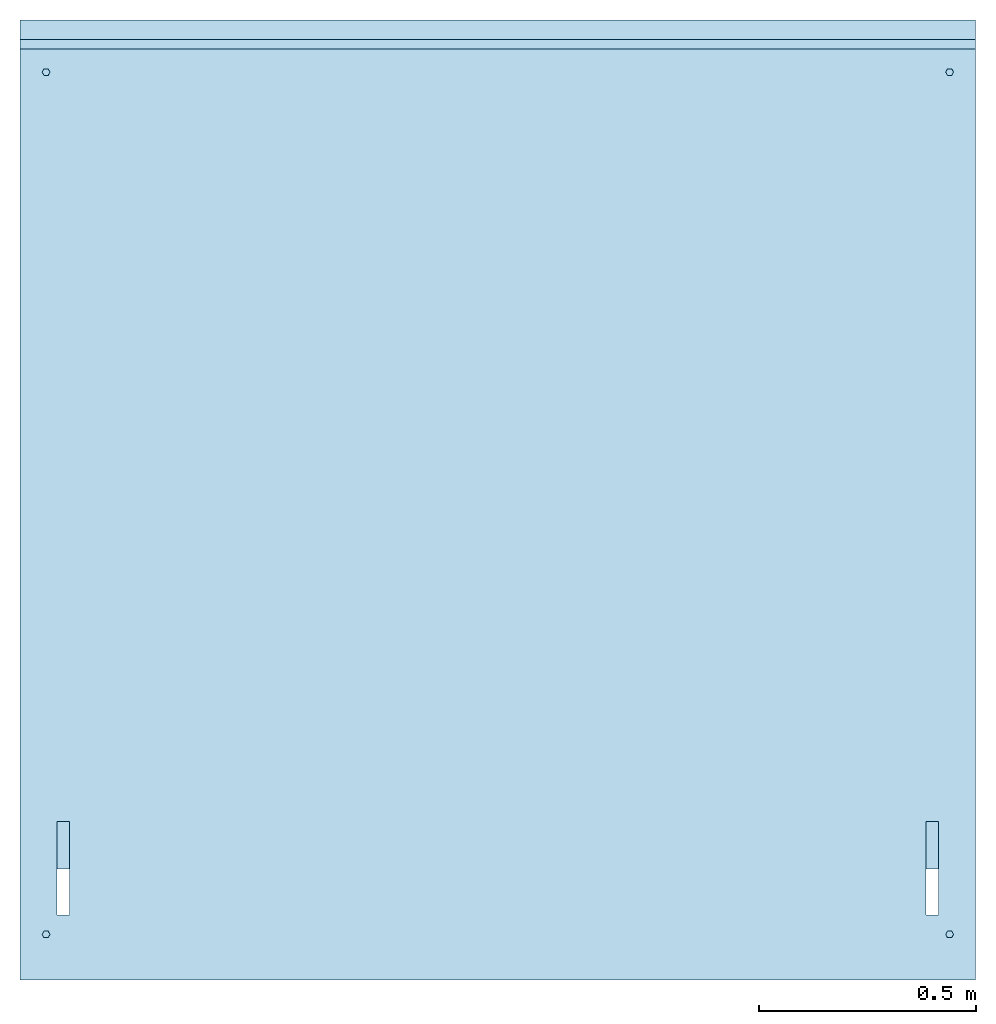
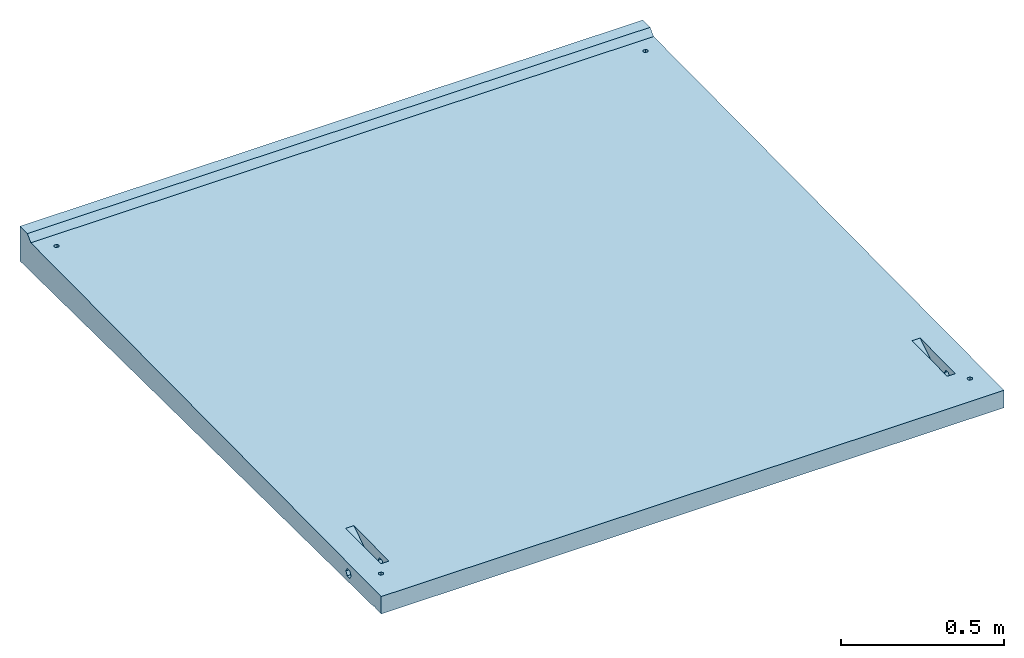
# One storey: 1 slab.
"""IFC2X3 building model written with IfcOpenShell, lengths in millimetres."""

import ifcopenshell
import ifcopenshell.guid

model = None  # the IFC model being written
_history = None  # IfcOwnerHistory: only IFC2X3 demands one
_inside = {}  # id of a spatial element -> (the spatial element, [elements in it])
_under = {}  # id of a project, library or spatial element -> (it, [spatial elements below it])
_declared = {}  # id of a project -> (the project, [libraries it declares])
_typed = {}  # id of a type object -> (the type object, [elements of that type])
_made_of = {}  # id of a material, layer set ... -> (it, [elements and type objects made of it])


def new_model(schema):
    """Start an empty IFC model of exactly this schema.

    Asked for "IFC4X3", IfcOpenShell would pick the latest addendum, in which some entities
    have other attributes; the version numbers below select the first issue.
    IFC2X3 requires an IfcOwnerHistory on every rooted entity: one is made here for all.
    """
    global model, _history
    if schema == "IFC4X3":
        model = ifcopenshell.file(schema_version=(4, 3, 0, 0))
    else:
        model = ifcopenshell.file(schema=schema)
    _inside.clear()
    _under.clear()
    _declared.clear()
    _typed.clear()
    _made_of.clear()
    _history = None
    if model.schema == "IFC2X3":
        org = make("IfcOrganization", Name="unknown")
        user = make(
            "IfcPersonAndOrganization",
            ThePerson=make("IfcPerson", FamilyName="unknown"),
            TheOrganization=org,
        )
        app = make(
            "IfcApplication",
            ApplicationDeveloper=org,
            Version="unknown",
            ApplicationFullName="unknown",
            ApplicationIdentifier="unknown",
        )
        _history = make(
            "IfcOwnerHistory",
            OwningUser=user,
            OwningApplication=app,
            ChangeAction="ADDED",
            CreationDate=0,
        )
    return model


def make(cls, **values):
    """One entity of the class cls with the attributes given. An attribute that is None is left unset."""
    return model.create_entity(
        cls, **{name: value for name, value in values.items() if value is not None}
    )


def entity(cls, *values):
    """Any entity or typed value of the class cls, its attributes in the order of the schema. None: left unset."""
    e = model.create_entity(cls)
    for i, value in enumerate(values):
        if value is not None:
            e[i] = value
    return e


def rooted(cls, **values):
    """An entity with a GlobalId (a new one), such as an element, a storey or a relation."""
    return make(cls, GlobalId=ifcopenshell.guid.new(), OwnerHistory=_history, **values)


def si_unit(unit_type, name, prefix=None):
    """IfcSIUnit, for example si_unit("LENGTHUNIT", "METRE", prefix="MILLI")."""
    return make("IfcSIUnit", UnitType=unit_type, Prefix=prefix, Name=name)


def converted_unit(unit_type, name, factor, base, dimensions=None, offset=None):
    """IfcConversionBasedUnit, such as the inch: factor (a typed value) times the base unit."""
    return make(
        "IfcConversionBasedUnit"
        if offset is None
        else "IfcConversionBasedUnitWithOffset",
        ConversionOffset=offset,
        Dimensions=None
        if dimensions is None
        else entity("IfcDimensionalExponents", *dimensions),
        UnitType=unit_type,
        Name=name,
        ConversionFactor=make(
            "IfcMeasureWithUnit", ValueComponent=factor, UnitComponent=base
        ),
    )


def derived_unit(unit_type, elements):
    """IfcDerivedUnit: a product of units, each with its exponent."""
    return make(
        "IfcDerivedUnit",
        Elements=[
            make("IfcDerivedUnitElement", Unit=unit, Exponent=power)
            for unit, power in elements
        ],
        UnitType=unit_type,
    )


def assignment(units):
    """IfcUnitAssignment: the units of a project."""
    return None if units is None else make("IfcUnitAssignment", Units=units)


def point(xyz):
    """IfcCartesianPoint."""
    return None if xyz is None else make("IfcCartesianPoint", Coordinates=xyz)


def direction(xyz):
    """IfcDirection."""
    return None if xyz is None else make("IfcDirection", DirectionRatios=xyz)


def frame(location, z_axis=None, x_axis=None):
    """IfcAxis2Placement3D, a coordinate frame: its origin and axes. An axis left out is left unset."""
    return make(
        "IfcAxis2Placement3D",
        Location=point(location),
        Axis=direction(z_axis),
        RefDirection=direction(x_axis),
    )


def origin():
    """The frame at (0, 0, 0) with its axes left unset."""
    return frame((0.0, 0.0, 0.0))


def place(relative_to, where):
    """IfcLocalPlacement: puts the frame where relative to a parent placement (None: the world)."""
    return make(
        "IfcLocalPlacement", PlacementRelTo=relative_to, RelativePlacement=where
    )


def context(
    kind, dimensions, precision=None, world=None, true_north=None, identifier=None
):
    """IfcGeometricRepresentationContext, for example the 3D "Model" context."""
    return make(
        "IfcGeometricRepresentationContext",
        ContextIdentifier=identifier,
        ContextType=kind,
        CoordinateSpaceDimension=dimensions,
        Precision=precision,
        WorldCoordinateSystem=world,
        TrueNorth=true_north,
    )


def subcontext(parent, identifier, kind, view, scale=None):
    """IfcGeometricRepresentationSubContext, for example "Body" below "Model"."""
    return make(
        "IfcGeometricRepresentationSubContext",
        ContextIdentifier=identifier,
        ContextType=kind,
        ParentContext=parent,
        TargetScale=scale,
        TargetView=view,
    )


def project(units=None, contexts=None):
    """IfcProject with its units and contexts."""
    return rooted(
        "IfcProject",
        Name="project",
        RepresentationContexts=contexts,
        UnitsInContext=assignment(units),
    )


def spatial(cls, under=None, at=None, **own):
    """A site, building, storey or space (cls), placed at a placement, below another one or the project."""
    s = rooted(cls, ObjectPlacement=at, **own)
    if under is not None:
        _under.setdefault(under.id(), (under, []))[1].append(s)
    return s


def faces_of(points, faces, orient=None, outer=None):
    """IfcFace entities. A face is a list of loops; a loop is a list of indices into points, from 0.

    orient and outer hold one flag for each loop. By default every Orientation is true, the
    first loop of a face is its IfcFaceOuterBound and the others are IfcFaceBound.
    """
    made = []
    for i, loops in enumerate(faces):
        bounds = []
        for j, loop in enumerate(loops):
            is_outer = j == 0 if outer is None else outer[i][j]
            bounds.append(
                make(
                    "IfcFaceOuterBound" if is_outer else "IfcFaceBound",
                    Bound=make("IfcPolyLoop", Polygon=[points[k] for k in loop]),
                    Orientation=True if orient is None else orient[i][j],
                )
            )
        made.append(make("IfcFace", Bounds=bounds))
    return made


def faceted_brep(points, faces, orient=None, outer=None, voids=None):
    """IfcFacetedBrep: a solid bounded by flat faces; with voids (closed shells), ...WithVoids."""
    shared = [point(p) for p in points]
    hull = make("IfcClosedShell", CfsFaces=faces_of(shared, faces, orient, outer))
    if voids is None:
        return make("IfcFacetedBrep", Outer=hull)
    return make(
        "IfcFacetedBrepWithVoids",
        Outer=hull,
        Voids=[
            make(cls, CfsFaces=faces_of(shared, fs, o, b)) for cls, fs, o, b in voids
        ],
    )


def shape(context_of_items, identifier, shape_type, items):
    """IfcShapeRepresentation: the items that make up one representation, for example the "Body"."""
    return make(
        "IfcShapeRepresentation",
        ContextOfItems=context_of_items,
        RepresentationIdentifier=identifier,
        RepresentationType=shape_type,
        Items=items,
    )


def material(Name=None, Category=None):
    """IfcMaterial."""
    return make("IfcMaterial", Name=Name, Category=Category)


def made_of(thing, what):
    """Note that an element or type object is made of a material, layer set ...; save() writes the relation."""
    if what is not None:
        _made_of.setdefault(what.id(), (what, []))[1].append(thing)
    return thing


def type_object(cls, material=None, **own):
    """A type object (cls), such as IfcWallType, which elements share."""
    return made_of(rooted(cls, **own), material)


def element(
    cls,
    number,
    at=None,
    inside=None,
    cuts=None,
    type_object=None,
    material=None,
    context=None,
    identifier="Body",
    shape_type=None,
    held_by="IfcProductDefinitionShape",
    body=None,
    shapes=None,
    **own,
):
    """One element of the class cls, such as IfcWall. Its Tag is "e" and its number.

    at: its placement. inside: the storey or other place that contains it. cuts: it is an
    opening in that element (IfcRelVoidsElement). A single representation is given by context,
    identifier, shape_type and body (its items); several are given by shapes. held_by: the class
    of the entity that holds the representations. save() writes the other relations.
    """
    e = rooted(cls, Tag="e%d" % number, ObjectPlacement=at, **own)
    if body is not None:
        shapes = [shape(context, identifier, shape_type, body)]
    if shapes is not None:
        e.Representation = make(held_by, Representations=shapes)
    if inside is not None:
        _inside.setdefault(inside.id(), (inside, []))[1].append(e)
    if cuts is not None:
        rooted(
            "IfcRelVoidsElement", RelatingBuildingElement=cuts, RelatedOpeningElement=e
        )
    if type_object is not None:
        _typed.setdefault(type_object.id(), (type_object, []))[1].append(e)
    return made_of(e, material)


def aggregate(whole, parts):
    """IfcRelAggregates: a whole, such as a stair, and the parts it consists of."""
    return rooted("IfcRelAggregates", RelatingObject=whole, RelatedObjects=parts)


def save(model, path):
    """Write the relations noted so far, then the file.

    IfcRelAggregates (storeys below a building ...), IfcRelContainedInSpatialStructure (elements
    in a storey), IfcRelDefinesByType, IfcRelAssociatesMaterial and IfcRelDeclares: one each for
    every whole, place, type object, material and project.
    """
    for whole, parts in _under.values():
        aggregate(whole, parts)
    for where, things in _inside.values():
        rooted(
            "IfcRelContainedInSpatialStructure",
            RelatedElements=things,
            RelatingStructure=where,
        )
    for kind, things in _typed.values():
        rooted("IfcRelDefinesByType", RelatedObjects=things, RelatingType=kind)
    for what, things in _made_of.values():
        rooted("IfcRelAssociatesMaterial", RelatedObjects=things, RelatingMaterial=what)
    for by, libraries in _declared.values():
        rooted("IfcRelDeclares", RelatingContext=by, RelatedDefinitions=libraries)
    model.write(path)


model = new_model("IFC2X3")

# Units and contexts
model_context = context("Model", 3, precision=0.01, world=origin(), true_north=direction((6.12303176911189e-17, 1.0)))
body_context = subcontext(model_context, "Body", "Model", "MODEL_VIEW")
ifc_project = project(units=[si_unit("LENGTHUNIT", "METRE", prefix="MILLI"), si_unit("AREAUNIT", "SQUARE_METRE"), si_unit("VOLUMEUNIT", "CUBIC_METRE"), converted_unit("PLANEANGLEUNIT", "DEGREE", entity("IfcRatioMeasure", 0.0174532925199433), si_unit("PLANEANGLEUNIT", "RADIAN"), dimensions=[0, 0, 0, 0, 0, 0, 0]), si_unit("MASSUNIT", "GRAM", prefix="KILO"), derived_unit("MASSDENSITYUNIT", [(si_unit("MASSUNIT", "GRAM", prefix="KILO"), 1), (si_unit("LENGTHUNIT", "METRE"), -3)]), derived_unit("MOMENTOFINERTIAUNIT", [(si_unit("LENGTHUNIT", "METRE"), 4)]), si_unit("TIMEUNIT", "SECOND"), si_unit("FREQUENCYUNIT", "HERTZ"), si_unit("THERMODYNAMICTEMPERATUREUNIT", "DEGREE_CELSIUS"), derived_unit("THERMALTRANSMITTANCEUNIT", [(si_unit("MASSUNIT", "GRAM", prefix="KILO"), 1), (si_unit("THERMODYNAMICTEMPERATUREUNIT", "KELVIN"), -1), (si_unit("TIMEUNIT", "SECOND"), -3)]), derived_unit("VOLUMETRICFLOWRATEUNIT", [(si_unit("LENGTHUNIT", "METRE"), 3), (si_unit("TIMEUNIT", "SECOND"), -1)]), si_unit("ELECTRICCURRENTUNIT", "AMPERE"), si_unit("ELECTRICVOLTAGEUNIT", "VOLT"), si_unit("POWERUNIT", "WATT"), si_unit("FORCEUNIT", "NEWTON", prefix="KILO"), si_unit("ILLUMINANCEUNIT", "LUX"), si_unit("LUMINOUSFLUXUNIT", "LUMEN"), si_unit("LUMINOUSINTENSITYUNIT", "CANDELA"), derived_unit("USERDEFINED", [(si_unit("MASSUNIT", "GRAM", prefix="KILO"), -1), (si_unit("LENGTHUNIT", "METRE"), -2), (si_unit("TIMEUNIT", "SECOND"), 3), (si_unit("LUMINOUSFLUXUNIT", "LUMEN"), 1)]), derived_unit("LINEARVELOCITYUNIT", [(si_unit("LENGTHUNIT", "METRE"), 1), (si_unit("TIMEUNIT", "SECOND"), -1)]), si_unit("PRESSUREUNIT", "PASCAL"), derived_unit("USERDEFINED", [(si_unit("LENGTHUNIT", "METRE"), -2), (si_unit("MASSUNIT", "GRAM", prefix="KILO"), 1), (si_unit("TIMEUNIT", "SECOND"), -2)]), derived_unit("LINEARFORCEUNIT", [(si_unit("MASSUNIT", "GRAM", prefix="KILO"), 1), (si_unit("LENGTHUNIT", "METRE"), 1), (si_unit("TIMEUNIT", "SECOND"), -2), (si_unit("LENGTHUNIT", "METRE"), -1)]), derived_unit("PLANARFORCEUNIT", [(si_unit("MASSUNIT", "GRAM", prefix="KILO"), 1), (si_unit("LENGTHUNIT", "METRE"), 1), (si_unit("TIMEUNIT", "SECOND"), -2), (si_unit("LENGTHUNIT", "METRE"), -2)])], contexts=[model_context])

# Site, building, storey
site_placement = place(None, origin())
site = spatial("IfcSite", under=ifc_project, at=site_placement, CompositionType="ELEMENT")
building_placement = place(site_placement, origin())
building = spatial("IfcBuilding", under=site, at=building_placement, CompositionType="ELEMENT")
storey_placement = place(building_placement, origin())
storey = spatial("IfcBuildingStorey", under=building, at=storey_placement, Name="Begane Grond", CompositionType="ELEMENT", Elevation=0.0)

# Slab
ifc_material = material(Name="beton_prefab-element")
slab_type = type_object("IfcSlabType", PredefinedType="FLOOR", material=ifc_material)
slab_placement = place(storey_placement, frame((4520.21359024522, -21298.0180129677, -54.5999999999827)))
element("IfcSlab", 1, at=slab_placement, inside=storey, type_object=slab_type, Name="23_GM_Standaard con R21:con, 2000x2200x65/115", PredefinedType="FLOOR", context=body_context, shape_type="Brep", body=[
    faceted_brep([(114.075534044746, 192.0, 38.2435935394484), (114.075534044746, 190.605222844009, 40.6594184388577), (114.075534044746, 189.210445688019, 43.075243338267), (114.075534044746, 186.60522284401, 47.5876216691333), (114.075534044746, 184.0, 52.0999999999995), (400.0, 184.0, 52.0999999999995), (400.0, 186.605222844123, 47.5876216689415), (400.0, 188.0, 45.171796769724), (400.0, 190.0, 41.7076951545862), (400.0, 192.0, 38.2435935394484), (2114.67446595528, 192.0, 38.2435935394484), (2114.67446595528, 190.182514765435, 41.3915703077247), (2114.67446595528, 188.365029530866, 44.539547076001), (2114.67446595528, 186.182514765432, 48.3197735380002), (2114.67446595528, 184.0, 52.0999999999995), (2200.0, 184.0, 52.0999999999995), (2200.0, 186.182514767502, 48.3197735344125), (2200.0, 188.0, 45.171796769724), (2200.0, 190.0, 41.7076951545862), (2200.0, 192.0, 38.2435935394484), (1800.0, 192.0, 38.2435935394484), (1800.0, 190.605222844009, 40.6594184388616), (1800.0, 189.210445688019, 43.0752433382748), (1800.0, 186.605222844006, 47.5876216691372), (1800.0, 184.0, 52.0999999999995), (2085.92446595528, 184.0, 52.0999999999994), (2085.92446595528, 186.605222844071, 47.5876216690292), (2085.92446595528, 188.0, 45.171796769724), (2085.92446595528, 190.0, 41.7076951545862), (2085.92446595528, 192.0, 38.2435935394484), (0.0, 192.0, 38.2435935394484), (0.0, 190.18251476158, 41.3915703143931), (0.0, 188.365029523165, 44.5395470893378), (0.0, 186.182514761581, 48.3197735446687), (0.0, 184.0, 52.0999999999995), (85.3255340447465, 184.0, 52.0999999999994), (85.3255340447465, 186.182514762088, 48.3197735437932), (85.3255340447465, 188.0, 45.171796769724), (85.3255340447465, 190.0, 41.7076951545862), (85.3255340447465, 192.0, 38.2435935394484), (400.0, 200.0, 38.2435935394484), (400.0, 204.0, 38.2435935394484), (400.0, 208.0, 38.2435935394483), (114.075534044746, 208.0, 38.2435935394483), (114.075534044746, 204.0, 38.2435935394484), (114.075534044746, 200.0, 38.2435935394484), (114.075534044746, 196.0, 38.2435935394484), (400.0, 196.0, 38.2435935394484), (2200.0, 200.0, 38.2435935394484), (2200.0, 204.0, 38.2435935394484), (2200.0, 208.0, 38.2435935394483), (2114.67446595528, 208.0, 38.2435935394483), (2114.67446595528, 204.0, 38.2435935394484), (2114.67446595528, 200.0, 38.2435935394484), (2114.67446595528, 196.0, 38.2435935394484), (2200.0, 196.0, 38.2435935394484), (2085.92446595528, 208.0, 38.2435935394483), (1800.0, 208.0, 38.2435935394483), (1800.0, 204.0, 38.2435935394484), (1800.0, 200.0, 38.2435935394484), (1800.0, 196.0, 38.2435935394484), (2085.92446595528, 196.0, 38.2435935394484), (2085.92446595528, 200.0, 38.2435935394484), (2085.92446595528, 204.0, 38.2435935394484), (85.3255340447465, 208.0, 38.2435935394483), (0.0, 208.0, 38.2435935394483), (0.0, 204.0, 38.2435935394484), (0.0, 200.0, 38.2435935394484), (0.0, 196.0, 38.2435935394484), (85.3255340447465, 196.0, 38.2435935394484), (85.3255340447465, 200.0, 38.2435935394484), (85.3255340447465, 204.0, 38.2435935394484), (400.0, 210.0, 41.7076951545861), (400.0, 212.0, 45.1717967697239), (400.0, 213.394777155964, 47.5876216690946), (400.0, 216.0, 52.0999999999994), (114.075534044746, 216.0, 52.0999999999993), (114.075534044746, 214.0, 48.6358983848615), (114.075534044746, 212.0, 45.1717967697238), (114.075534044746, 210.0, 41.7076951545861), (2200.0, 210.0, 41.7076951545861), (2200.0, 212.0, 45.1717967697238), (2200.0, 213.817485237315, 48.3197735427603), (2200.0, 216.0, 52.0999999999994), (2114.67446595528, 216.0, 52.0999999999993), (2114.67446595528, 214.0, 48.6358983848615), (2114.67446595528, 212.0, 45.1717967697238), (2114.67446595528, 210.0, 41.7076951545861), (1800.0, 214.0, 48.6358983848615), (1800.0, 212.0, 45.1717967697238), (1800.0, 210.0, 41.7076951545861), (2085.92446595528, 210.0, 41.7076951545861), (2085.92446595528, 212.0, 45.1717967697239), (2085.92446595528, 213.394777155977, 47.5876216691147), (2085.92446595528, 216.0, 52.0999999999994), (1800.0, 216.0, 52.0999999999995), (0.0, 214.0, 48.6358983848615), (0.0, 212.0, 45.1717967697238), (0.0, 210.0, 41.7076951545861), (85.3255340447465, 210.0, 41.7076951545861), (85.3255340447465, 212.0, 45.1717967697238), (85.3255340447465, 213.817485238354, 48.3197735445614), (85.3255340447465, 216.0, 52.0999999999994), (0.0, 216.0, 52.0999999999996), (114.075534044746, 200.0, 65.9564064605506), (114.075534044746, 204.0, 65.9564064605506), (114.075534044746, 208.0, 65.9564064605506), (400.0, 208.0, 65.9564064605506), (400.0, 204.0, 65.9564064605506), (400.0, 200.0, 65.9564064605506), (400.0, 196.0, 65.9564064605506), (400.0, 192.0, 65.9564064605506), (114.075534044746, 192.0, 65.9564064605506), (114.075534044746, 196.0, 65.9564064605506), (2114.67446595528, 200.0, 65.9564064605506), (2114.67446595528, 204.0, 65.9564064605506), (2114.67446595528, 208.0, 65.9564064605506), (2200.0, 208.0, 65.9564064605506), (2200.0, 204.0, 65.9564064605506), (2200.0, 200.0, 65.9564064605506), (2200.0, 196.0, 65.9564064605506), (2200.0, 192.0, 65.9564064605506), (2114.67446595528, 192.0, 65.9564064605506), (2114.67446595528, 196.0, 65.9564064605506), (2085.92446595528, 192.0, 65.9564064605505), (1800.0, 192.0, 65.9564064605506), (1800.0, 196.0, 65.9564064605506), (1800.0, 200.0, 65.9564064605506), (1800.0, 204.0, 65.9564064605506), (1800.0, 208.0, 65.9564064605506), (2085.92446595528, 208.0, 65.9564064605506), (2085.92446595528, 204.0, 65.9564064605506), (2085.92446595528, 200.0, 65.9564064605506), (2085.92446595528, 196.0, 65.9564064605506), (85.3255340447465, 192.0, 65.9564064605505), (0.0, 192.0, 65.9564064605505), (0.0, 196.0, 65.9564064605506), (0.0, 200.0, 65.9564064605506), (0.0, 204.0, 65.9564064605506), (0.0, 208.0, 65.9564064605506), (85.3255340447465, 208.0, 65.9564064605506), (85.3255340447465, 204.0, 65.9564064605506), (85.3255340447465, 200.0, 65.9564064605506), (85.3255340447465, 196.0, 65.9564064605506), (400.0, 210.0, 62.4923048454128), (114.075534044746, 210.0, 62.4923048454128), (114.075534044746, 212.0, 59.028203230275), (114.075534044746, 214.0, 55.5641016151372), (400.0, 213.3947771302, 56.6123783755319), (400.0, 212.0, 59.028203230275), (2200.0, 212.0, 59.0282032302751), (2200.0, 210.0, 62.4923048454128), (2114.67446595528, 210.0, 62.4923048454128), (2114.67446595528, 212.0, 59.028203230275), (2114.67446595528, 214.0, 55.5641016151372), (2200.0, 213.817485194138, 55.8802265320185), (1800.0, 210.0, 62.4923048454128), (1800.0, 212.0, 59.028203230275), (1800.0, 214.0, 55.5641016151372), (2085.92446595528, 213.394777127467, 56.6123783802622), (2085.92446595528, 212.0, 59.0282032302751), (2085.92446595528, 210.0, 62.4923048454128), (85.3255340447465, 210.0, 62.4923048454128), (0.0, 210.0, 62.4923048454128), (0.0, 212.0, 59.028203230275), (0.0, 214.0, 55.5641016151372), (85.325534044747, 213.817485136482, 55.8802266318781), (85.3255340447465, 212.0, 59.0282032302751), (114.075534044746, 190.0, 62.4923048454128), (400.0, 190.605222844269, 63.5405815615906), (400.0, 189.210445688539, 61.1247566626306), (400.0, 186.605222844266, 56.6123783313151), (114.075534044746, 186.605222844014, 56.6123783308729), (114.075534044746, 188.0, 59.028203230275), (2114.67446595528, 188.0, 59.028203230275), (2114.67446595528, 190.0, 62.4923048454128), (2200.0, 190.0, 62.4923048454128), (2200.0, 188.0, 59.028203230275), (2200.0, 186.182514768477, 55.8802264672793), (2114.67446595528, 186.0, 55.5641016151373), (1800.0, 188.0, 59.028203230275), (1800.0, 190.0, 62.4923048454128), (2085.92446595528, 190.0, 62.4923048454128), (2085.92446595528, 188.0, 59.028203230275), (2085.92446595528, 186.605222844153, 56.6123783311158), (1800.0, 186.0, 55.5641016151373), (85.3255340447465, 190.0, 62.4923048454128), (85.3255340447465, 188.0, 59.028203230275), (85.3255340447465, 186.182514762205, 55.8802264564145), (0.0, 186.0, 55.5641016151373), (0.0, 188.0, 59.028203230275), (0.0, 190.0, 62.4923048454128), (64.500000000001, 97.2057713659394, 48.0600005145843), (69.0, 105.0, 48.0600005145843), (64.500000000001, 112.794228634056, 48.0600005145843), (55.5000000000009, 112.794228634056, 48.0600005145843), (51.0, 105.0, 48.0600005145843), (55.5000000000009, 97.2057713659394, 48.0600005145843), (2135.5, 112.794228634056, 48.0600005145843), (2131.0, 105.0, 48.0600005145843), (2135.5, 97.2057713659394, 48.0600005145843), (2144.5, 97.2057713659394, 48.0600005145843), (2149.0, 105.0, 48.0600005145843), (2144.5, 112.794228634056, 48.0600005145843), (51.0, 2090.0, 67.9100005145707), (55.5000000000004, 2082.20577136594, 67.9100005145707), (64.5000000000005, 2082.20577136594, 67.9100005145707), (69.0, 2090.0, 67.9100005145707), (64.5000000000005, 2097.79422863406, 67.9100005145707), (55.5000000000004, 2097.79422863406, 67.9100005145707), (2131.0, 2090.0, 67.9100005145707), (2135.5, 2082.20577136594, 67.9100005145707), (2144.5, 2082.20577136594, 67.9100005145707), (2149.0, 2090.0, 67.9100005145707), (2144.5, 2097.79422863406, 67.9100005145707), (2135.5, 2097.79422863406, 67.9100005145707), (0.0, 2210.0, 0.0), (0.0, 44.9997500187486, 21.6500024998128), (0.0, 2143.53535353534, 108.535353535339), (0.0, 0.0, 87.1000000000002), (0.0, 42.5431741146631, 26.0049117787142), (0.0, 37.5434240959141, 26.0549092789018), (0.0, 0.0, 22.1000000000001), (0.0, 35.0002499812506, 21.7499975001876), (0.0, 2210.0, 130.0), (0.0, 2165.0, 130.0), (2200.0, 44.9997500187486, 21.6500024998126), (2200.0, 2210.0, 0.0), (2200.0, 42.5431741146631, 26.0049117787142), (2200.0, 2143.53535353534, 108.535353535339), (2200.0, 2210.0, 130.0), (2200.0, 2165.0, 130.0), (2200.0, 0.0, 87.1000000000002), (2200.0, 37.5434240959141, 26.0549092789018), (2200.0, 0.0, 22.1000000000001), (2200.0, 35.0002499812506, 21.7499975001877), (54.8874172794205, 97.5931452069581, 88.0759314520691), (51.0, 105.0, 88.1499999999995), (65.112582720581, 97.5931452069581, 88.0759314520691), (85.3255340447465, 365.0, 90.7499999999978), (114.075534044746, 150.0, 88.5999999999992), (2085.92446595528, 150.0, 88.5999999999992), (2134.88741727942, 97.5931452069581, 88.0759314520691), (2145.11258272058, 97.5931452069581, 88.0759314520691), (2149.0, 105.0, 88.1499999999995), (2114.67446595528, 365.0, 90.7499999999978), (2134.88741727942, 2097.40685479304, 108.074068547917), (2145.11258272058, 2097.40685479304, 108.074068547917), (2149.0, 2090.0, 108.0), (2145.11258272058, 2082.59314520696, 107.925931452056), (2145.11258272058, 112.406854793042, 88.2240685479299), (2114.67446595528, 150.0, 88.5999999999992), (2134.88741727942, 2082.59314520696, 107.925931452056), (2085.92446595528, 365.0, 90.7499999999978), (2131.0, 105.0, 88.1499999999995), (2134.88741727942, 112.406854793042, 88.2240685479299), (69.0, 105.0, 88.1499999999995), (85.3255340447465, 150.0, 88.5999999999992), (114.075534044746, 365.0, 90.7499999999978), (65.112582720581, 112.406854793042, 88.2240685479299), (54.8874172794205, 112.406854793042, 88.2240685479299), (54.8874172794205, 2082.59314520696, 107.925931452056), (65.112582720581, 2082.59314520696, 107.925931452056), (51.0, 2090.0, 108.0), (54.8874172794205, 2097.40685479304, 108.074068547917), (65.112582720581, 2097.40685479304, 108.074068547917), (2131.0, 2090.0, 108.0), (69.0, 2090.0, 108.0), (114.075534044746, 255.0, 19.5500000000001), (85.3255340447465, 255.0, 19.5500000000001), (2085.92446595528, 255.0, 19.5500000000001), (2114.67446595528, 255.0, 19.5500000000001), (2114.67446595528, 150.0, 20.6000000000001), (2085.92446595528, 150.0, 20.6000000000001), (85.3255340447465, 150.0, 20.6000000000001), (114.075534044746, 150.0, 20.6000000000001)], [[[0, 1, 2, 3, 4, 5, 6, 7, 8, 9]], [[10, 11, 12, 13, 14, 15, 16, 17, 18, 19]], [[20, 21, 22, 23, 24, 25, 26, 27, 28, 29]], [[30, 31, 32, 33, 34, 35, 36, 37, 38, 39]], [[40, 41, 42, 43, 44, 45, 46, 0, 9, 47]], [[48, 49, 50, 51, 52, 53, 54, 10, 19, 55]], [[56, 57, 58, 59, 60, 20, 29, 61, 62, 63]], [[64, 65, 66, 67, 68, 30, 39, 69, 70, 71]], [[43, 42, 72, 73, 74, 75, 76, 77, 78, 79]], [[51, 50, 80, 81, 82, 83, 84, 85, 86, 87]], [[88, 89, 90, 57, 56, 91, 92, 93, 94, 95]], [[96, 97, 98, 65, 64, 99, 100, 101, 102, 103]], [[104, 105, 106, 107, 108, 109, 110, 111, 112, 113]], [[114, 115, 116, 117, 118, 119, 120, 121, 122, 123]], [[124, 125, 126, 127, 128, 129, 130, 131, 132, 133]], [[134, 135, 136, 137, 138, 139, 140, 141, 142, 143]], [[144, 107, 106, 145, 146, 147, 76, 75, 148, 149]], [[150, 151, 117, 116, 152, 153, 154, 84, 83, 155]], [[156, 157, 158, 95, 94, 159, 160, 161, 130, 129]], [[162, 140, 139, 163, 164, 165, 103, 102, 166, 167]], [[168, 112, 111, 169, 170, 171, 5, 4, 172, 173]], [[174, 175, 122, 121, 176, 177, 178, 15, 14, 179]], [[180, 181, 125, 124, 182, 183, 184, 25, 24, 185]], [[135, 134, 186, 187, 188, 35, 34, 189, 190, 191]], [[192, 193, 194, 195, 196, 197]], [[198, 199, 200, 201, 202, 203]], [[204, 205, 206, 207, 208, 209]], [[210, 211, 212, 213, 214, 215]], [[65, 216, 217]], [[65, 218, 216]], [[218, 65, 98]], [[217, 66, 65]], [[218, 98, 97]], [[218, 97, 96]], [[218, 96, 103]], [[218, 103, 165]], [[218, 165, 164]], [[218, 164, 163]], [[218, 163, 139]], [[139, 219, 218]], [[219, 139, 138]], [[219, 138, 137]], [[219, 137, 136]], [[219, 136, 135]], [[135, 220, 219]], [[220, 135, 191]], [[220, 191, 190]], [[220, 190, 189]], [[220, 189, 34]], [[34, 217, 220]], [[217, 34, 33]], [[217, 33, 32]], [[217, 32, 31]], [[217, 31, 30]], [[217, 30, 68]], [[217, 68, 67]], [[217, 67, 66]], [[220, 221, 219]], [[219, 221, 222]], [[221, 223, 222]], [[224, 216, 218]], [[218, 225, 224]], [[226, 227, 50]], [[226, 50, 49]], [[226, 49, 48]], [[226, 48, 55]], [[226, 55, 19]], [[226, 19, 18]], [[226, 18, 17]], [[226, 17, 16]], [[226, 16, 15]], [[228, 226, 15]], [[227, 229, 50]], [[229, 227, 230]], [[230, 231, 229]], [[229, 80, 50]], [[229, 81, 80]], [[229, 82, 81]], [[229, 83, 82]], [[229, 155, 83]], [[229, 150, 155]], [[229, 151, 150]], [[229, 117, 151]], [[229, 232, 117]], [[232, 233, 228]], [[234, 233, 232]], [[232, 228, 121]], [[232, 121, 120]], [[232, 120, 119]], [[232, 119, 118]], [[232, 118, 117]], [[234, 235, 233]], [[228, 15, 178]], [[228, 178, 177]], [[228, 177, 176]], [[228, 176, 121]], [[219, 222, 234, 232]], [[219, 236, 237]], [[236, 219, 238]], [[219, 237, 239]], [[238, 219, 240]], [[219, 241, 240]], [[218, 219, 239]], [[241, 219, 232]], [[232, 242, 241]], [[232, 243, 242]], [[243, 232, 244]], [[232, 245, 244]], [[245, 232, 229]], [[246, 229, 218]], [[246, 247, 229]], [[229, 247, 248]], [[248, 249, 229]], [[249, 245, 229]], [[250, 244, 245]], [[251, 250, 245]], [[245, 249, 252]], [[253, 245, 252]], [[251, 241, 254]], [[254, 255, 251]], [[255, 250, 251]], [[254, 241, 242]], [[241, 253, 240]], [[256, 238, 240]], [[257, 256, 240]], [[240, 253, 258]], [[256, 257, 259]], [[259, 257, 260]], [[260, 257, 239]], [[237, 260, 239]], [[261, 218, 239]], [[239, 258, 262]], [[239, 262, 261]], [[261, 263, 218]], [[264, 218, 263]], [[218, 264, 265]], [[218, 265, 246]], [[266, 246, 265]], [[265, 267, 266]], [[266, 267, 262]], [[262, 258, 252]], [[266, 262, 252]], [[252, 258, 253]], [[216, 224, 230, 227]], [[216, 268, 269]], [[268, 216, 227]], [[216, 269, 217]], [[227, 270, 268]], [[270, 227, 271]], [[271, 227, 226]], [[226, 272, 271]], [[273, 272, 226]], [[273, 226, 217]], [[274, 217, 269]], [[217, 274, 275]], [[217, 275, 273]], [[270, 273, 275]], [[268, 270, 275]], [[222, 223, 235, 234]], [[226, 228, 220, 217]], [[228, 233, 221, 220]], [[233, 235, 223, 221]], [[225, 218, 229, 231]], [[224, 225, 231, 230]], [[240, 106, 105]], [[240, 258, 106]], [[240, 105, 104]], [[240, 104, 113]], [[240, 113, 112]], [[240, 112, 168]], [[240, 168, 173]], [[240, 173, 172]], [[240, 172, 4]], [[240, 4, 275]], [[258, 145, 106]], [[258, 146, 145]], [[258, 147, 146]], [[258, 76, 147]], [[268, 76, 258]], [[268, 275, 43]], [[268, 43, 79]], [[268, 79, 78]], [[268, 78, 77]], [[268, 77, 76]], [[275, 4, 3]], [[275, 3, 2]], [[275, 2, 1]], [[275, 1, 0]], [[275, 0, 46]], [[275, 46, 45]], [[275, 45, 44]], [[275, 44, 43]], [[274, 39, 38]], [[274, 38, 37]], [[274, 37, 36]], [[274, 36, 35]], [[257, 274, 35]], [[274, 69, 39]], [[274, 70, 69]], [[274, 71, 70]], [[274, 64, 71]], [[269, 64, 274]], [[269, 99, 64]], [[269, 100, 99]], [[269, 101, 100]], [[269, 102, 101]], [[269, 239, 102]], [[257, 140, 239]], [[239, 140, 162]], [[239, 162, 167]], [[239, 167, 166]], [[239, 166, 102]], [[257, 35, 188]], [[257, 188, 187]], [[257, 187, 186]], [[257, 186, 134]], [[257, 134, 143]], [[257, 143, 142]], [[257, 142, 141]], [[257, 141, 140]], [[257, 240, 275, 274]], [[241, 251, 272, 273]], [[269, 268, 258, 239]], [[270, 271, 245, 253]], [[251, 116, 115]], [[251, 245, 116]], [[251, 115, 114]], [[251, 114, 123]], [[251, 123, 122]], [[251, 122, 175]], [[251, 175, 174]], [[251, 174, 179]], [[251, 179, 14]], [[251, 14, 272]], [[245, 152, 116]], [[245, 153, 152]], [[245, 154, 153]], [[245, 84, 154]], [[271, 84, 245]], [[271, 272, 51]], [[271, 51, 87]], [[271, 87, 86]], [[271, 86, 85]], [[271, 85, 84]], [[272, 14, 13]], [[272, 13, 12]], [[272, 12, 11]], [[272, 11, 10]], [[272, 10, 54]], [[272, 54, 53]], [[272, 53, 52]], [[272, 52, 51]], [[273, 29, 28]], [[273, 28, 27]], [[273, 27, 26]], [[273, 26, 25]], [[241, 273, 25]], [[273, 61, 29]], [[273, 62, 61]], [[273, 63, 62]], [[273, 56, 63]], [[270, 56, 273]], [[270, 91, 56]], [[270, 92, 91]], [[270, 93, 92]], [[270, 94, 93]], [[270, 253, 94]], [[241, 130, 253]], [[253, 130, 161]], [[253, 161, 160]], [[253, 160, 159]], [[253, 159, 94]], [[241, 25, 184]], [[241, 184, 183]], [[241, 183, 182]], [[241, 182, 124]], [[241, 124, 133]], [[241, 133, 132]], [[241, 132, 131]], [[241, 131, 130]], [[23, 22, 21, 20, 60, 59, 58, 57, 90, 89, 88, 95, 158, 157, 156, 129, 128, 127, 126, 125, 181, 180, 185, 24]], [[41, 40, 47, 9, 8, 7, 6, 5, 171, 170, 169, 111, 110, 109, 108, 107, 144, 149, 148, 75, 74, 73, 72, 42]], [[236, 197, 196]], [[196, 237, 236]], [[236, 238, 192, 197]], [[242, 243, 201, 200]], [[238, 193, 192]], [[193, 238, 256]], [[259, 194, 193]], [[193, 256, 259]], [[259, 260, 195, 194]], [[250, 255, 198, 203]], [[260, 196, 195]], [[196, 260, 237]], [[242, 200, 199]], [[199, 254, 242]], [[243, 202, 201]], [[202, 243, 244]], [[250, 203, 202]], [[202, 244, 250]], [[255, 199, 198]], [[199, 255, 254]], [[261, 205, 204]], [[204, 263, 261]], [[261, 262, 206, 205]], [[252, 249, 212, 211]], [[262, 207, 206]], [[207, 262, 267]], [[265, 208, 207]], [[207, 267, 265]], [[265, 264, 209, 208]], [[247, 246, 215, 214]], [[264, 204, 209]], [[204, 264, 263]], [[252, 211, 210]], [[210, 266, 252]], [[249, 213, 212]], [[213, 249, 248]], [[247, 214, 213]], [[213, 248, 247]], [[246, 210, 215]], [[210, 246, 266]]]),
])

save(model, "model.ifc")
